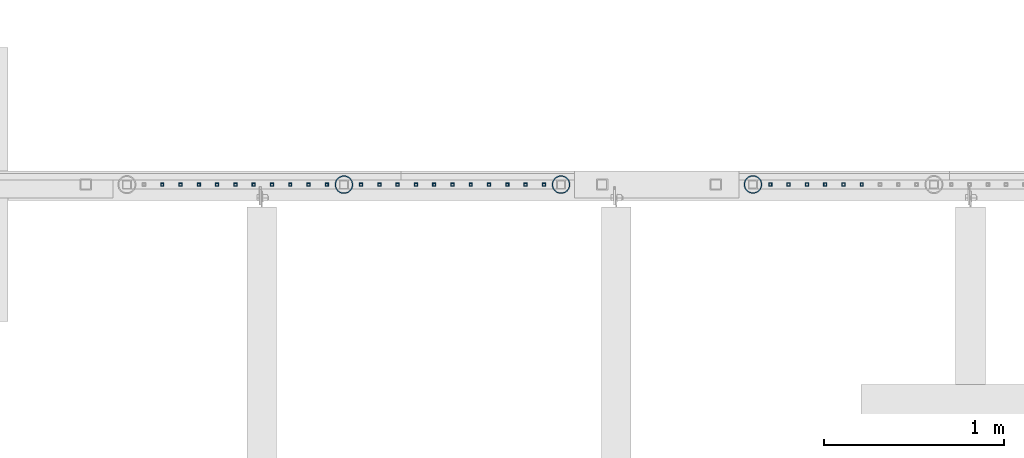
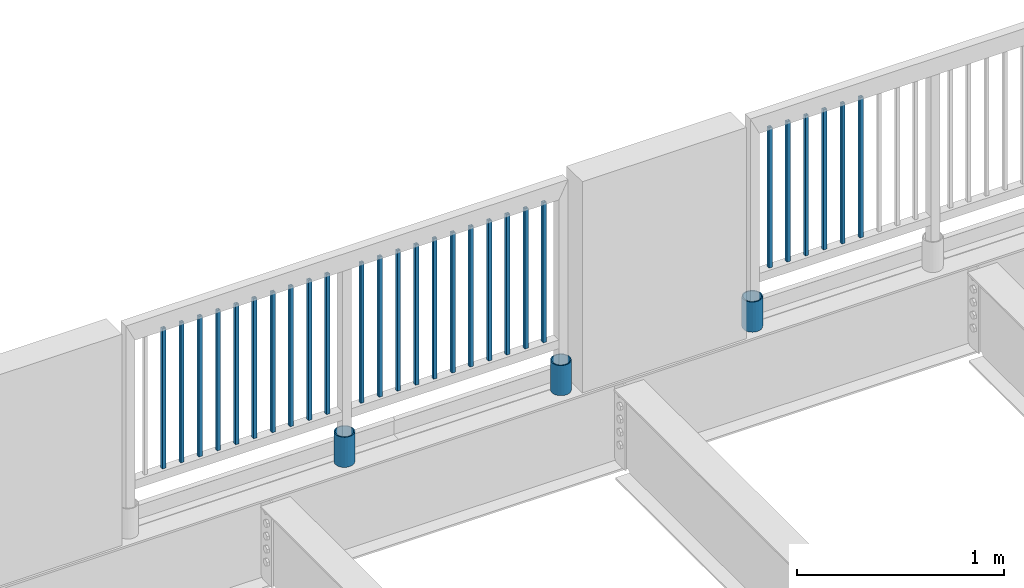
# One storey, part 232 of 975: 30 columns.
"""IFC2X3 building model written with IfcOpenShell, lengths in millimetres."""

from ifc_helpers import new_model, si_unit, frame, origin_with_axes, place, context, subcontext, project, spatial, faceted_brep, material, type_object, element, save


model = new_model("IFC2X3")

# Units and contexts
model_context = context("Model", 3, precision=1e-05, world=origin_with_axes())
body_context = subcontext(model_context, "Body", "Model", "MODEL_VIEW")
ifc_project = project(units=[si_unit("LENGTHUNIT", "METRE", prefix="MILLI"), si_unit("AREAUNIT", "SQUARE_METRE"), si_unit("VOLUMEUNIT", "CUBIC_METRE"), si_unit("MASSUNIT", "GRAM", prefix="KILO"), si_unit("TIMEUNIT", "SECOND"), si_unit("PLANEANGLEUNIT", "RADIAN"), si_unit("SOLIDANGLEUNIT", "STERADIAN"), si_unit("THERMODYNAMICTEMPERATUREUNIT", "DEGREE_CELSIUS"), si_unit("LUMINOUSINTENSITYUNIT", "LUMEN")], contexts=[model_context])

# Site, building, storey
site_placement = place(None, origin_with_axes())
site = spatial("IfcSite", under=ifc_project, at=site_placement, CompositionType="ELEMENT")
building_placement = place(site_placement, origin_with_axes())
building = spatial("IfcBuilding", under=site, at=building_placement, Name="Undefined", CompositionType="ELEMENT")
storey_placement = place(building_placement, origin_with_axes())
storey = spatial("IfcBuildingStorey", under=building, at=storey_placement, Name="Undefined", CompositionType="ELEMENT", Elevation=0.0)

# Columns
ifc_material_1 = material()
column_type_1 = type_object("IfcColumnType", Name="HSS3/4X3/4X.120_TUBES", PredefinedType="NOTDEFINED")
for number, where, z_axis, x_axis, name in (
    (1, (7624.4478301234, 29962.3688078713, 4254.49165791356), (1.0, 0.0, 0.0), (0.0, 0.0, 1.0), "PICKET"),
    (2, (7522.8478301234, 29962.3688078713, 4254.49165791356), (1.0, 0.0, 0.0), (0.0, 0.0, 1.0), "PICKET"),
    (3, (7421.24783012341, 29962.3688078713, 4254.49165791356), (1.0, 0.0, 0.0), (0.0, 0.0, 1.0), "PICKET"),
    (4, (7319.6478301234, 29962.3688078713, 4254.49165791356), (1.0, 0.0, 0.0), (0.0, 0.0, 1.0), "PICKET"),
    (5, (7218.04783012341, 29962.3688078713, 4254.49165791356), (1.0, 0.0, 0.0), (0.0, 0.0, 1.0), "PICKET"),
    (6, (7116.4478301234, 29962.3688078713, 4254.49165791356), (1.0, 0.0, 0.0), (0.0, 0.0, 1.0), "PICKET"),
    (7, (5857.87930694032, 29961.6762605771, 4254.49826760429), (1.0, 0.0, 0.0), (0.0, 0.0, 1.0), "PICKET"),
    (8, (5756.27930694032, 29961.6762605771, 4254.49826760429), (1.0, 0.0, 0.0), (0.0, 0.0, 1.0), "PICKET"),
    (9, (5654.67930694032, 29961.6762605771, 4254.49826760429), (1.0, 0.0, 0.0), (0.0, 0.0, 1.0), "PICKET"),
    (10, (5553.07930694032, 29961.6762605771, 4254.49826760429), (1.0, 0.0, 0.0), (0.0, 0.0, 1.0), "PICKET"),
    (11, (5451.47930694032, 29961.6762605771, 4254.49826760429), (1.0, 0.0, 0.0), (0.0, 0.0, 1.0), "PICKET"),
    (12, (5349.87930694032, 29961.6762605771, 4254.49826760429), (1.0, 0.0, 0.0), (0.0, 0.0, 1.0), "PICKET"),
    (13, (5248.27930694032, 29961.6762605771, 4254.49826760429), (1.0, 0.0, 0.0), (0.0, 0.0, 1.0), "PICKET"),
    (14, (5146.67930694032, 29961.6762605771, 4254.49826760429), (1.0, 0.0, 0.0), (0.0, 0.0, 1.0), "PICKET"),
    (15, (5045.07930694032, 29961.6762605771, 4254.49826760429), (1.0, 0.0, 0.0), (0.0, 0.0, 1.0), "PICKET"),
    (16, (4943.47930694032, 29961.6762605771, 4254.49826760429), (1.0, 0.0, 0.0), (0.0, 0.0, 1.0), "PICKET"),
    (17, (4841.87930694032, 29961.6762605771, 4254.49826760429), (1.0, 0.0, 0.0), (0.0, 0.0, 1.0), "PICKET"),
    (18, (4651.37664058602, 29961.7455061682, 4254.49906094201), (1.0, 0.0, 0.0), (0.0, 0.0, 1.0), "PICKET"),
    (19, (4549.77664058602, 29961.7455061682, 4254.49906094201), (1.0, 0.0, 0.0), (0.0, 0.0, 1.0), "PICKET"),
    (20, (4448.17664058602, 29961.7455061682, 4254.49906094201), (1.0, 0.0, 0.0), (0.0, 0.0, 1.0), "PICKET"),
    (21, (4346.57664058602, 29961.7455061682, 4254.49906094201), (1.0, 0.0, 0.0), (0.0, 0.0, 1.0), "PICKET"),
    (22, (4244.97664058602, 29961.7455061682, 4254.49906094201), (1.0, 0.0, 0.0), (0.0, 0.0, 1.0), "PICKET"),
    (23, (4143.37664058602, 29961.7455061682, 4254.49906094201), (1.0, 0.0, 0.0), (0.0, 0.0, 1.0), "PICKET"),
    (24, (4041.77664058602, 29961.7455061682, 4254.49906094201), (1.0, 0.0, 0.0), (0.0, 0.0, 1.0), "PICKET"),
    (25, (3940.17664058602, 29961.7455061682, 4254.49906094201), (1.0, 0.0, 0.0), (0.0, 0.0, 1.0), "PICKET"),
    (26, (3838.57664058602, 29961.7455061682, 4254.49906094201), (1.0, 0.0, 0.0), (0.0, 0.0, 1.0), "PICKET"),
    (27, (3736.97664058602, 29961.7455061682, 4254.49906094201), (1.0, 0.0, 0.0), (0.0, 0.0, 1.0), "PICKET"),
):
    element("IfcColumn", number, at=place(storey_placement, frame(where, z_axis=z_axis, x_axis=x_axis)), inside=storey, type_object=column_type_1, material=ifc_material_1, Name=name, ObjectType="HSS3/4X3/4X.120_TUBES", context=body_context, shape_type="Brep", body=[
        faceted_brep([(0.0, 6.34999999998763, -6.34999999998763), (0.0, -6.35000000000582, -6.34999999998763), (825.49997943247, -6.35000000000582, -6.34999999998763), (825.49997943247, 6.34999999998763, -6.34999999998763), (0.0, -6.34999999998763, 6.34999999998763), (825.49997943247, -6.34999999998763, 6.34999999998763), (0.0, 6.35000000000946, 6.34999999998763), (825.49997943247, 6.35000000000946, 6.34999999998763), (0.0, 9.52499999997963, -9.52499999997963), (0.0, 9.52500000000873, 9.5249999999869), (825.49997943247, 9.52500000000873, 9.5249999999869), (825.49997943247, 9.52499999997963, -9.52499999997963), (0.0, -9.52499999997963, 9.52499999998327), (825.49997943247, -9.52499999997963, 9.52499999998327), (0.0, -9.52500000000873, -9.5249999999869), (825.49997943247, -9.52500000000873, -9.5249999999869)], [[[0, 1, 2, 3]], [[1, 4, 5, 2]], [[4, 6, 7, 5]], [[6, 0, 3, 7]], [[8, 9, 10, 11]], [[9, 12, 13, 10]], [[12, 14, 15, 13]], [[14, 8, 11, 15]], [[13, 15, 11, 10], [5, 7, 3, 2]], [[14, 12, 9, 8], [6, 4, 1, 0]]]),
    ])
ifc_material_2 = material(Name="STEEL/A53")
column_type_2 = type_object("IfcColumnType", Name="PIPE3-1/2STD", PredefinedType="NOTDEFINED")
column_1_placement = place(storey_placement, frame((4746.62702976621, 29961.7244176431, 3937.0), z_axis=(-0.707106781186601, 0.707106781186494, 2.36468622460961e-14), x_axis=(0.0, 0.0, 1.0)))
element("IfcColumn", 28, at=column_1_placement, inside=storey, type_object=column_type_2, material=ifc_material_2, ObjectType="PIPE3-1/2STD", context=body_context, shape_type="Brep", body=[
    faceted_brep([(0.0, -45.0595999999932, 1.45519152283669e-11), (0.0, -42.8542262016344, 13.924182159768), (177.8, -42.8542262016344, 13.924182159768), (177.8, -45.0595999999932, 1.45519152283669e-11), (0.0, -36.45398215971, 26.4853683542424), (177.8, -36.45398215971, 26.4853683542424), (0.0, -26.4853683541623, 36.45398215979), (177.8, -26.4853683541623, 36.45398215979), (0.0, -13.9241821596988, 42.8542262017108), (177.8, -13.9241821596988, 42.8542262017108), (0.0, 3.63797880709171e-11, 45.0596000000514), (177.8, 3.63797880709171e-11, 45.0596000000514), (0.0, 13.9241821597716, 42.8542262017036), (177.8, 13.9241821597716, 42.8542262017036), (0.0, 26.4853683542242, 36.4539821597718), (177.8, 26.4853683542242, 36.4539821597718), (0.0, 36.4539821597537, 26.4853683542206), (177.8, 36.4539821597537, 26.4853683542206), (0.0, 42.8542262016563, 13.9241821597425), (177.8, 42.8542262016563, 13.9241821597425), (0.0, 45.0595999999932, -1.09139364212751e-11), (177.8, 45.0595999999932, -1.09139364212751e-11), (0.0, 42.8542262016344, -13.9241821597643), (177.8, 42.8542262016344, -13.9241821597643), (0.0, 36.45398215971, -26.4853683542387), (177.8, 36.45398215971, -26.4853683542387), (0.0, 26.4853683541623, -36.4539821597864), (177.8, 26.4853683541623, -36.4539821597864), (0.0, 13.9241821596988, -42.8542262017072), (177.8, 13.9241821596988, -42.8542262017072), (0.0, -3.63797880709171e-11, -45.0596000000478), (177.8, -3.63797880709171e-11, -45.0596000000478), (0.0, -13.9241821597716, -42.8542262016963), (177.8, -13.9241821597716, -42.8542262016963), (0.0, -26.4853683542242, -36.4539821597682), (177.8, -26.4853683542242, -36.4539821597682), (0.0, -36.4539821597537, -26.4853683542169), (177.8, -36.4539821597537, -26.4853683542169), (0.0, -42.8542262016563, -13.9241821597352), (177.8, -42.8542262016563, -13.9241821597352), (0.0, -50.799999999992, 1.81898940354586e-11), (0.0, -48.3136710278013, -15.6980633142484), (177.8, -48.3136710278013, -15.6980633142484), (177.8, -50.799999999992, 1.81898940354586e-11), (0.0, -41.0980633142644, -29.8594908164741), (177.8, -41.0980633142644, -29.8594908164741), (0.0, -29.859490816485, -41.0980633142826), (177.8, -29.859490816485, -41.0980633142826), (0.0, -15.6980633142848, -48.313671027845), (177.8, -15.6980633142848, -48.313671027845), (0.0, -4.36557456851006e-11, -50.8000000000575), (177.8, -4.36557456851006e-11, -50.8000000000575), (0.0, 15.6980633142011, -48.3136710278523), (177.8, 15.6980633142011, -48.3136710278523), (0.0, 29.8594908164159, -41.0980633143045), (177.8, 29.8594908164159, -41.0980633143045), (0.0, 41.0980633142135, -29.8594908165032), (177.8, 41.0980633142135, -29.8594908165032), (0.0, 48.3136710277722, -15.6980633142775), (177.8, 48.3136710277722, -15.6980633142775), (0.0, 50.799999999992, -1.45519152283669e-11), (177.8, 50.799999999992, -1.45519152283669e-11), (0.0, 48.313671027794, 15.6980633142521), (177.8, 48.313671027794, 15.6980633142521), (0.0, 41.0980633142644, 29.8594908164814), (177.8, 41.0980633142644, 29.8594908164814), (0.0, 29.859490816485, 41.0980633142863), (177.8, 29.859490816485, 41.0980633142863), (0.0, 15.6980633142848, 48.3136710278486), (177.8, 15.6980633142848, 48.3136710278486), (0.0, 4.00177668780088e-11, 50.8000000000611), (177.8, 4.00177668780088e-11, 50.8000000000611), (0.0, -15.6980633142011, 48.3136710278559), (177.8, -15.6980633142011, 48.3136710278559), (0.0, -29.8594908164159, 41.0980633143081), (177.8, -29.8594908164159, 41.0980633143081), (0.0, -41.0980633142171, 29.8594908165069), (177.8, -41.0980633142171, 29.8594908165069), (0.0, -48.3136710277722, 15.6980633142812), (177.8, -48.3136710277722, 15.6980633142812)], [[[0, 1, 2, 3]], [[1, 4, 5, 2]], [[4, 6, 7, 5]], [[6, 8, 9, 7]], [[8, 10, 11, 9]], [[10, 12, 13, 11]], [[12, 14, 15, 13]], [[14, 16, 17, 15]], [[16, 18, 19, 17]], [[18, 20, 21, 19]], [[20, 22, 23, 21]], [[22, 24, 25, 23]], [[24, 26, 27, 25]], [[26, 28, 29, 27]], [[28, 30, 31, 29]], [[30, 32, 33, 31]], [[32, 34, 35, 33]], [[34, 36, 37, 35]], [[36, 38, 39, 37]], [[38, 0, 3, 39]], [[40, 41, 42, 43]], [[41, 44, 45, 42]], [[44, 46, 47, 45]], [[46, 48, 49, 47]], [[48, 50, 51, 49]], [[50, 52, 53, 51]], [[52, 54, 55, 53]], [[54, 56, 57, 55]], [[56, 58, 59, 57]], [[58, 60, 61, 59]], [[60, 62, 63, 61]], [[62, 64, 65, 63]], [[64, 66, 67, 65]], [[66, 68, 69, 67]], [[68, 70, 71, 69]], [[70, 72, 73, 71]], [[72, 74, 75, 73]], [[74, 76, 77, 75]], [[76, 78, 79, 77]], [[78, 40, 43, 79]], [[45, 47, 49, 51, 53, 55, 57, 59, 61, 63, 65, 67, 69, 71, 73, 75, 77, 79, 43, 42], [5, 7, 9, 11, 13, 15, 17, 19, 21, 23, 25, 27, 29, 31, 33, 35, 37, 39, 3, 2]], [[78, 76, 74, 72, 70, 68, 66, 64, 62, 60, 58, 56, 54, 52, 50, 48, 46, 44, 41, 40], [38, 36, 34, 32, 30, 28, 26, 24, 22, 20, 18, 16, 14, 12, 10, 8, 6, 4, 1, 0]]]),
])
column_2_placement = place(storey_placement, frame((5953.26945393299, 29961.9826933994, 3937.0), z_axis=(-0.707106781186601, 0.707106781186494, 2.36468622460961e-14), x_axis=(0.0, 0.0, 1.0)))
element("IfcColumn", 29, at=column_2_placement, inside=storey, type_object=column_type_2, material=ifc_material_2, ObjectType="PIPE3-1/2STD", context=body_context, shape_type="Brep", body=[
    faceted_brep([(0.0, -45.0595999999932, 1.45519152283669e-11), (0.0, -42.8542262016344, 13.924182159768), (177.8, -42.8542262016344, 13.924182159768), (177.8, -45.0595999999932, 1.45519152283669e-11), (0.0, -36.45398215971, 26.4853683542424), (177.8, -36.45398215971, 26.4853683542424), (0.0, -26.4853683541623, 36.45398215979), (177.8, -26.4853683541623, 36.45398215979), (0.0, -13.9241821596988, 42.8542262017108), (177.8, -13.9241821596988, 42.8542262017108), (0.0, 3.63797880709171e-11, 45.0596000000514), (177.8, 3.63797880709171e-11, 45.0596000000514), (0.0, 13.9241821597716, 42.8542262017036), (177.8, 13.9241821597716, 42.8542262017036), (0.0, 26.4853683542242, 36.4539821597718), (177.8, 26.4853683542242, 36.4539821597718), (0.0, 36.4539821597537, 26.4853683542206), (177.8, 36.4539821597537, 26.4853683542206), (0.0, 42.8542262016563, 13.9241821597425), (177.8, 42.8542262016563, 13.9241821597425), (0.0, 45.0595999999932, -1.09139364212751e-11), (177.8, 45.0595999999932, -1.09139364212751e-11), (0.0, 42.8542262016344, -13.9241821597643), (177.8, 42.8542262016344, -13.9241821597643), (0.0, 36.45398215971, -26.4853683542387), (177.8, 36.45398215971, -26.4853683542387), (0.0, 26.4853683541623, -36.4539821597864), (177.8, 26.4853683541623, -36.4539821597864), (0.0, 13.9241821596988, -42.8542262017072), (177.8, 13.9241821596988, -42.8542262017072), (0.0, -3.63797880709171e-11, -45.0596000000478), (177.8, -3.63797880709171e-11, -45.0596000000478), (0.0, -13.9241821597716, -42.8542262016963), (177.8, -13.9241821597716, -42.8542262016963), (0.0, -26.4853683542242, -36.4539821597682), (177.8, -26.4853683542242, -36.4539821597682), (0.0, -36.4539821597537, -26.4853683542169), (177.8, -36.4539821597537, -26.4853683542169), (0.0, -42.8542262016563, -13.9241821597352), (177.8, -42.8542262016563, -13.9241821597352), (0.0, -50.799999999992, 1.81898940354586e-11), (0.0, -48.3136710278013, -15.6980633142484), (177.8, -48.3136710278013, -15.6980633142484), (177.8, -50.799999999992, 1.81898940354586e-11), (0.0, -41.0980633142644, -29.8594908164741), (177.8, -41.0980633142644, -29.8594908164741), (0.0, -29.859490816485, -41.0980633142826), (177.8, -29.859490816485, -41.0980633142826), (0.0, -15.6980633142848, -48.313671027845), (177.8, -15.6980633142848, -48.313671027845), (0.0, -4.36557456851006e-11, -50.8000000000575), (177.8, -4.36557456851006e-11, -50.8000000000575), (0.0, 15.6980633142011, -48.3136710278523), (177.8, 15.6980633142011, -48.3136710278523), (0.0, 29.8594908164159, -41.0980633143045), (177.8, 29.8594908164159, -41.0980633143045), (0.0, 41.0980633142135, -29.8594908165032), (177.8, 41.0980633142135, -29.8594908165032), (0.0, 48.3136710277722, -15.6980633142775), (177.8, 48.3136710277722, -15.6980633142775), (0.0, 50.799999999992, -1.45519152283669e-11), (177.8, 50.799999999992, -1.45519152283669e-11), (0.0, 48.313671027794, 15.6980633142521), (177.8, 48.313671027794, 15.6980633142521), (0.0, 41.0980633142644, 29.8594908164814), (177.8, 41.0980633142644, 29.8594908164814), (0.0, 29.859490816485, 41.0980633142863), (177.8, 29.859490816485, 41.0980633142863), (0.0, 15.6980633142848, 48.3136710278486), (177.8, 15.6980633142848, 48.3136710278486), (0.0, 4.00177668780088e-11, 50.8000000000611), (177.8, 4.00177668780088e-11, 50.8000000000611), (0.0, -15.6980633142011, 48.3136710278559), (177.8, -15.6980633142011, 48.3136710278559), (0.0, -29.8594908164159, 41.0980633143081), (177.8, -29.8594908164159, 41.0980633143081), (0.0, -41.0980633142171, 29.8594908165069), (177.8, -41.0980633142171, 29.8594908165069), (0.0, -48.3136710277722, 15.6980633142812), (177.8, -48.3136710277722, 15.6980633142812)], [[[0, 1, 2, 3]], [[1, 4, 5, 2]], [[4, 6, 7, 5]], [[6, 8, 9, 7]], [[8, 10, 11, 9]], [[10, 12, 13, 11]], [[12, 14, 15, 13]], [[14, 16, 17, 15]], [[16, 18, 19, 17]], [[18, 20, 21, 19]], [[20, 22, 23, 21]], [[22, 24, 25, 23]], [[24, 26, 27, 25]], [[26, 28, 29, 27]], [[28, 30, 31, 29]], [[30, 32, 33, 31]], [[32, 34, 35, 33]], [[34, 36, 37, 35]], [[36, 38, 39, 37]], [[38, 0, 3, 39]], [[40, 41, 42, 43]], [[41, 44, 45, 42]], [[44, 46, 47, 45]], [[46, 48, 49, 47]], [[48, 50, 51, 49]], [[50, 52, 53, 51]], [[52, 54, 55, 53]], [[54, 56, 57, 55]], [[56, 58, 59, 57]], [[58, 60, 61, 59]], [[60, 62, 63, 61]], [[62, 64, 65, 63]], [[64, 66, 67, 65]], [[66, 68, 69, 67]], [[68, 70, 71, 69]], [[70, 72, 73, 71]], [[72, 74, 75, 73]], [[74, 76, 77, 75]], [[76, 78, 79, 77]], [[78, 40, 43, 79]], [[45, 47, 49, 51, 53, 55, 57, 59, 61, 63, 65, 67, 69, 71, 73, 75, 77, 79, 43, 42], [5, 7, 9, 11, 13, 15, 17, 19, 21, 23, 25, 27, 29, 31, 33, 35, 37, 39, 3, 2]], [[78, 76, 74, 72, 70, 68, 66, 64, 62, 60, 58, 56, 54, 52, 50, 48, 46, 44, 41, 40], [38, 36, 34, 32, 30, 28, 26, 24, 22, 20, 18, 16, 14, 12, 10, 8, 6, 4, 1, 0]]]),
])
column_3_placement = place(storey_placement, frame((7020.06661879212, 29962.7459439167, 3937.0), z_axis=(-0.707106781186601, 0.707106781186494, 2.36468622460961e-14), x_axis=(0.0, 0.0, 1.0)))
element("IfcColumn", 30, at=column_3_placement, inside=storey, type_object=column_type_2, material=ifc_material_2, ObjectType="PIPE3-1/2STD", context=body_context, shape_type="Brep", body=[
    faceted_brep([(0.0, -45.0595999999932, 1.45519152283669e-11), (0.0, -42.8542262016344, 13.924182159768), (177.8, -42.8542262016344, 13.924182159768), (177.8, -45.0595999999932, 1.45519152283669e-11), (0.0, -36.45398215971, 26.4853683542424), (177.8, -36.45398215971, 26.4853683542424), (0.0, -26.4853683541623, 36.45398215979), (177.8, -26.4853683541623, 36.45398215979), (0.0, -13.9241821596988, 42.8542262017108), (177.8, -13.9241821596988, 42.8542262017108), (0.0, 3.63797880709171e-11, 45.0596000000514), (177.8, 3.63797880709171e-11, 45.0596000000514), (0.0, 13.9241821597716, 42.8542262017036), (177.8, 13.9241821597716, 42.8542262017036), (0.0, 26.4853683542242, 36.4539821597718), (177.8, 26.4853683542242, 36.4539821597718), (0.0, 36.4539821597537, 26.4853683542206), (177.8, 36.4539821597537, 26.4853683542206), (0.0, 42.8542262016563, 13.9241821597425), (177.8, 42.8542262016563, 13.9241821597425), (0.0, 45.0595999999932, -1.09139364212751e-11), (177.8, 45.0595999999932, -1.09139364212751e-11), (0.0, 42.8542262016344, -13.9241821597643), (177.8, 42.8542262016344, -13.9241821597643), (0.0, 36.45398215971, -26.4853683542387), (177.8, 36.45398215971, -26.4853683542387), (0.0, 26.4853683541623, -36.4539821597864), (177.8, 26.4853683541623, -36.4539821597864), (0.0, 13.9241821596988, -42.8542262017072), (177.8, 13.9241821596988, -42.8542262017072), (0.0, -3.63797880709171e-11, -45.0596000000478), (177.8, -3.63797880709171e-11, -45.0596000000478), (0.0, -13.9241821597716, -42.8542262016963), (177.8, -13.9241821597716, -42.8542262016963), (0.0, -26.4853683542242, -36.4539821597682), (177.8, -26.4853683542242, -36.4539821597682), (0.0, -36.4539821597537, -26.4853683542169), (177.8, -36.4539821597537, -26.4853683542169), (0.0, -42.8542262016563, -13.9241821597352), (177.8, -42.8542262016563, -13.9241821597352), (0.0, -50.799999999992, 1.81898940354586e-11), (0.0, -48.3136710278013, -15.6980633142484), (177.8, -48.3136710278013, -15.6980633142484), (177.8, -50.799999999992, 1.81898940354586e-11), (0.0, -41.0980633142644, -29.8594908164741), (177.8, -41.0980633142644, -29.8594908164741), (0.0, -29.859490816485, -41.0980633142826), (177.8, -29.859490816485, -41.0980633142826), (0.0, -15.6980633142848, -48.313671027845), (177.8, -15.6980633142848, -48.313671027845), (0.0, -4.36557456851006e-11, -50.8000000000575), (177.8, -4.36557456851006e-11, -50.8000000000575), (0.0, 15.6980633142011, -48.3136710278523), (177.8, 15.6980633142011, -48.3136710278523), (0.0, 29.8594908164159, -41.0980633143045), (177.8, 29.8594908164159, -41.0980633143045), (0.0, 41.0980633142135, -29.8594908165032), (177.8, 41.0980633142135, -29.8594908165032), (0.0, 48.3136710277722, -15.6980633142775), (177.8, 48.3136710277722, -15.6980633142775), (0.0, 50.799999999992, -1.45519152283669e-11), (177.8, 50.799999999992, -1.45519152283669e-11), (0.0, 48.313671027794, 15.6980633142521), (177.8, 48.313671027794, 15.6980633142521), (0.0, 41.0980633142644, 29.8594908164814), (177.8, 41.0980633142644, 29.8594908164814), (0.0, 29.859490816485, 41.0980633142863), (177.8, 29.859490816485, 41.0980633142863), (0.0, 15.6980633142848, 48.3136710278486), (177.8, 15.6980633142848, 48.3136710278486), (0.0, 4.00177668780088e-11, 50.8000000000611), (177.8, 4.00177668780088e-11, 50.8000000000611), (0.0, -15.6980633142011, 48.3136710278559), (177.8, -15.6980633142011, 48.3136710278559), (0.0, -29.8594908164159, 41.0980633143081), (177.8, -29.8594908164159, 41.0980633143081), (0.0, -41.0980633142171, 29.8594908165069), (177.8, -41.0980633142171, 29.8594908165069), (0.0, -48.3136710277722, 15.6980633142812), (177.8, -48.3136710277722, 15.6980633142812)], [[[0, 1, 2, 3]], [[1, 4, 5, 2]], [[4, 6, 7, 5]], [[6, 8, 9, 7]], [[8, 10, 11, 9]], [[10, 12, 13, 11]], [[12, 14, 15, 13]], [[14, 16, 17, 15]], [[16, 18, 19, 17]], [[18, 20, 21, 19]], [[20, 22, 23, 21]], [[22, 24, 25, 23]], [[24, 26, 27, 25]], [[26, 28, 29, 27]], [[28, 30, 31, 29]], [[30, 32, 33, 31]], [[32, 34, 35, 33]], [[34, 36, 37, 35]], [[36, 38, 39, 37]], [[38, 0, 3, 39]], [[40, 41, 42, 43]], [[41, 44, 45, 42]], [[44, 46, 47, 45]], [[46, 48, 49, 47]], [[48, 50, 51, 49]], [[50, 52, 53, 51]], [[52, 54, 55, 53]], [[54, 56, 57, 55]], [[56, 58, 59, 57]], [[58, 60, 61, 59]], [[60, 62, 63, 61]], [[62, 64, 65, 63]], [[64, 66, 67, 65]], [[66, 68, 69, 67]], [[68, 70, 71, 69]], [[70, 72, 73, 71]], [[72, 74, 75, 73]], [[74, 76, 77, 75]], [[76, 78, 79, 77]], [[78, 40, 43, 79]], [[45, 47, 49, 51, 53, 55, 57, 59, 61, 63, 65, 67, 69, 71, 73, 75, 77, 79, 43, 42], [5, 7, 9, 11, 13, 15, 17, 19, 21, 23, 25, 27, 29, 31, 33, 35, 37, 39, 3, 2]], [[78, 76, 74, 72, 70, 68, 66, 64, 62, 60, 58, 56, 54, 52, 50, 48, 46, 44, 41, 40], [38, 36, 34, 32, 30, 28, 26, 24, 22, 20, 18, 16, 14, 12, 10, 8, 6, 4, 1, 0]]]),
])

save(model, "model.ifc")
